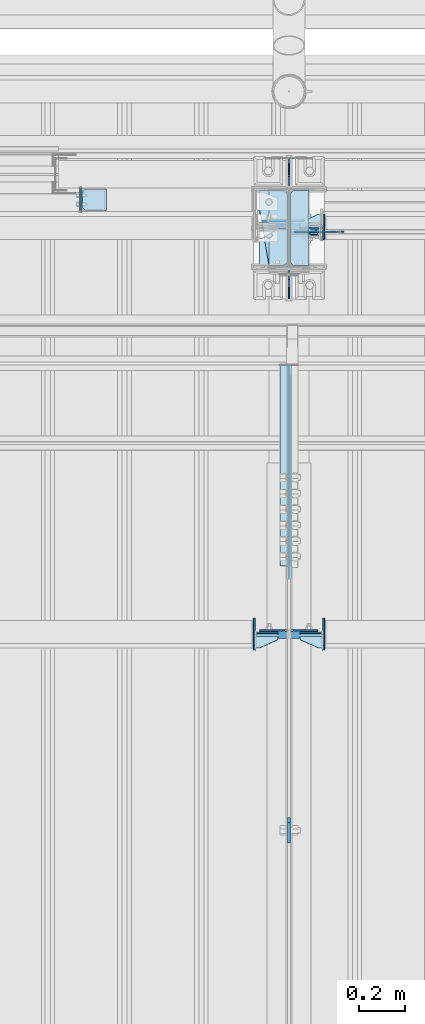
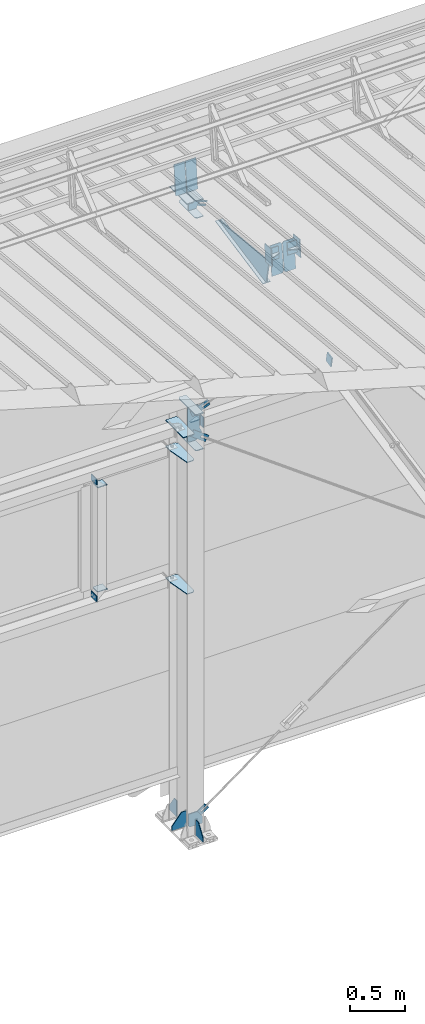
# One storey, part 139 of 709: 38 plates, 13 elements without a shape of their own.
"""IFC4 building model written with IfcOpenShell, lengths in millimetres."""

from ifc_helpers import new_model, si_unit, direction, frame, origin_with_axes, place, context, subcontext, project, spatial, line, indexed_curve, outline, extrude, material, element, aggregate, save


model = new_model("IFC4")

# Units and contexts
model_context = context("Model", 3, precision=0.2, world=origin_with_axes(), true_north=direction((0.0, 1.0)))
body_context = subcontext(model_context, "Body", "Model", "MODEL_VIEW")
ifc_project = project(units=[si_unit("LENGTHUNIT", "METRE", prefix="MILLI"), si_unit("AREAUNIT", "SQUARE_METRE"), si_unit("VOLUMEUNIT", "CUBIC_METRE"), si_unit("MASSUNIT", "GRAM", prefix="KILO"), si_unit("TIMEUNIT", "SECOND"), si_unit("PLANEANGLEUNIT", "RADIAN"), si_unit("SOLIDANGLEUNIT", "STERADIAN"), si_unit("THERMODYNAMICTEMPERATUREUNIT", "DEGREE_CELSIUS"), si_unit("LUMINOUSINTENSITYUNIT", "LUMEN")], contexts=[model_context])

# Site, building, storey
site_placement = place(None, origin_with_axes())
site = spatial("IfcSite", under=ifc_project, at=site_placement, CompositionType="ELEMENT")
building_placement = place(site_placement, origin_with_axes())
building = spatial("IfcBuilding", under=site, at=building_placement, Name="Undefined", CompositionType="ELEMENT")
storey_placement = place(building_placement, origin_with_axes())
storey = spatial("IfcBuildingStorey", under=building, at=storey_placement, Name="Undefined", CompositionType="ELEMENT", Elevation=0.0)

# Assembly, plates
assembly_1_placement = place(storey_placement, frame((22000.0, 21654.0, 7089.70002), z_axis=(-1.0, 0.0, 0.0), x_axis=(0.0, -0.9950371902, 0.099503719)))
assembly_1 = element("IfcElementAssembly", 1, at=assembly_1_placement, inside=storey)
ifc_material = material(Name="C355-6", Category="STEEL")
plate_1_placement = place(assembly_1_placement, frame((1597.88359, 163.0, -127.0), z_axis=(1.0, 0.0, 0.0), x_axis=(0.0, 0.0, 1.0)))
plate_1 = element("IfcPlate", 2, at=plate_1_placement, material=ifc_material, ObjectType="585", context=body_context, shape_type="SolidModel", body=[
    extrude(outline(indexed_curve([(0.0, 0.0), (108.0, 0.0), (123.0, 15.0), (123.0, 311.0), (108.0, 326.0), (0.0, 326.0)], segments=[line(1, 2, 3, 4, 5, 6, 1)])), frame((0.0, 0.0, 4.0), z_axis=(0.0, 0.0, 1.0), x_axis=(1.0, 0.0, 0.0)), (0.0, 0.0, -1.0), 8.0),
])
plate_2_placement = place(assembly_1_placement, frame((1597.88359, 163.0, 127.0), z_axis=(-1.0, 0.0, 0.0), x_axis=(0.0, 0.0, -1.0)))
plate_2 = element("IfcPlate", 3, at=plate_2_placement, material=ifc_material, ObjectType="585", context=body_context, shape_type="SolidModel", body=[
    extrude(outline(indexed_curve([(0.0, 0.0), (108.0, 0.0), (123.0, 15.0), (123.0, 311.0), (108.0, 326.0), (0.0, 326.0)], segments=[line(1, 2, 3, 4, 5, 6, 1)])), frame((0.0, 0.0, 4.0), z_axis=(0.0, 0.0, 1.0), x_axis=(1.0, 0.0, 0.0)), (0.0, 0.0, -1.0), 8.0),
])
plate_3_placement = place(assembly_1_placement, frame((1336.51563, -171.28713, 0.0), z_axis=(0.0, 0.0, 1.0), x_axis=(-1.0, 0.0, 0.0)))
plate_3 = element("IfcPlate", 4, at=plate_3_placement, material=ifc_material, ObjectType="449", context=body_context, shape_type="SolidModel", body=[
    extrude(outline(indexed_curve([(0.0, 0.0), (928.3198, 0.0), (79.53997, 259.83056)], segments=[line(1, 2, 3, 1)])), frame((0.0, 0.0, 6.0), z_axis=(0.0, 0.0, 1.0), x_axis=(1.0, 0.0, 0.0)), (0.0, 0.0, -1.0), 12.0),
])
plate_4_placement = place(assembly_1_placement, frame((1255.8048, -434.94249, -40.0), z_axis=(0.2927142719, 0.9561999556, 0.0), x_axis=(-0.9561999556, 0.2927142719, 0.0)))
plate_4 = element("IfcPlate", 5, at=plate_4_placement, material=ifc_material, ObjectType="450", context=body_context, shape_type="SolidModel", body=[
    extrude(outline(indexed_curve([(0.0, 0.0), (887.65935, 0.0), (887.65935, 80.0), (0.0, 80.0)], segments=[line(1, 2, 3, 4, 1)])), frame((0.0, 0.0, 4.0), z_axis=(0.0, 0.0, 1.0), x_axis=(1.0, 0.0, 0.0)), (0.0, 0.0, -1.0), 8.0),
])
aggregate(assembly_1, [plate_1, plate_2, plate_3, plate_4])

# Assembly, plate
assembly_2_placement = place(storey_placement, frame((22000.0, 19245.35924, 6685.17103), z_axis=(1.0, 0.0, 0.0), x_axis=(0.0, -0.9805806757, -0.1961161349)))
assembly_2 = element("IfcElementAssembly", 6, at=assembly_2_placement, inside=storey)
plate_5_placement = place(assembly_2_placement, origin_with_axes())
plate_5 = element("IfcPlate", 7, at=plate_5_placement, material=ifc_material, ObjectType="491", context=body_context, shape_type="SolidModel", body=[
    extrude(outline(indexed_curve([(0.0, 0.0), (90.0, 0.0), (90.0, 110.0), (0.0, 110.0)], segments=[line(1, 2, 3, 4, 1)])), frame((0.0, 0.0, 6.0), z_axis=(0.0, 0.0, 1.0), x_axis=(1.0, 0.0, 0.0)), (0.0, 0.0, -1.0), 12.0),
])
aggregate(assembly_2, [plate_5])

# Assembly, plates
assembly_3_placement = place(storey_placement, frame((28000.0, 21827.0, 4310.0), z_axis=(0.0, 0.0, -1.0), x_axis=(-1.0, 0.0, 0.0)))
assembly_3 = element("IfcElementAssembly", 8, at=assembly_3_placement, inside=storey)
plate_6_placement = place(assembly_3_placement, frame((5849.0, -50.0, -60.0), z_axis=(1.0, 0.0, 0.0), x_axis=(0.0, 1.0, 0.0)))
plate_6 = element("IfcPlate", 9, at=plate_6_placement, material=ifc_material, ObjectType="519", context=body_context, shape_type="SolidModel", body=[
    extrude(outline(indexed_curve([(0.0, 0.0), (110.0, 0.0), (110.0, 120.0), (0.0, 120.0)], segments=[line(1, 2, 3, 4, 1)])), frame((0.0, 0.0, 4.0), z_axis=(0.0, 0.0, 1.0), x_axis=(1.0, 0.0, 0.0)), (0.0, 0.0, -1.0), 8.0),
])
plate_7_placement = place(assembly_3_placement, frame((5953.0, 60.0, 0.0), z_axis=(0.0, 0.0, -1.0), x_axis=(0.0, -1.0, 0.0)))
plate_7 = element("IfcPlate", 10, at=plate_7_placement, material=ifc_material, ObjectType="521", context=body_context, shape_type="SolidModel", body=[
    extrude(outline(indexed_curve([(0.0, 80.0), (36.0, 0.0), (56.0, 0.0), (56.0, 90.0), (46.0, 100.0), (0.0, 100.0)], segments=[line(1, 2, 3, 4, 5, 6, 1)])), frame((0.0, 0.0, 4.0), z_axis=(0.0, 0.0, 1.0), x_axis=(1.0, 0.0, 0.0)), (0.0, 0.0, -1.0), 8.0),
])
plate_8_placement = place(assembly_3_placement, frame((5953.0, 0.0, -60.0), z_axis=(0.0, -1.0, 0.0), x_axis=(0.0, 0.0, 1.0)))
plate_8 = element("IfcPlate", 11, at=plate_8_placement, material=ifc_material, ObjectType="520", context=body_context, shape_type="SolidModel", body=[
    extrude(outline(indexed_curve([(0.0, 0.0), (120.0, 0.0), (120.0, 100.0), (0.0, 100.0)], segments=[line(1, 2, 3, 4, 1)])), frame((0.0, 0.0, 4.0), z_axis=(0.0, 0.0, 1.0), x_axis=(1.0, 0.0, 0.0)), (0.0, 0.0, -1.0), 8.0),
])
aggregate(assembly_3, [plate_6, plate_7, plate_8])

# Assembly, plate
assembly_4_placement = place(storey_placement, frame((26870.92374, 21811.0, 672.76012), z_axis=(0.0, 1.0, 0.0), x_axis=(-0.8064830392, 0.0, 0.5912572262)))
assembly_4 = element("IfcElementAssembly", 12, at=assembly_4_placement, inside=storey)
plate_9_placement = place(assembly_4_placement, frame((5781.83429, 35.0, 0.0), z_axis=(0.0, 0.0, -1.0), x_axis=(1.0, 0.0, 0.0)))
plate_9 = element("IfcPlate", 13, at=plate_9_placement, material=ifc_material, ObjectType="525", context=body_context, shape_type="SolidModel", body=[
    extrude(outline(indexed_curve([(0.0, 0.0), (200.0, 0.0), (200.0, 70.0), (0.0, 70.0), (0.0, 46.0), (80.0, 46.0), (80.0, 24.0), (0.0, 24.0)], segments=[line(1, 2, 3, 4, 5, 6, 7, 8, 1)])), frame((0.0, 0.0, 4.0), z_axis=(0.0, 0.0, 1.0), x_axis=(1.0, 0.0, 0.0)), (0.0, 0.0, -1.0), 8.0),
])
aggregate(assembly_4, [plate_9])

assembly_5_placement = place(storey_placement, frame((23129.07626, 21811.0, 672.76012), z_axis=(0.0, 1.0, 0.0), x_axis=(-0.8064830392, 0.0, -0.5912572261)))
assembly_5 = element("IfcElementAssembly", 14, at=assembly_5_placement, inside=storey)
plate_10_placement = place(assembly_5_placement, frame((1145.82155, 11.0, 0.0), z_axis=(0.0, 0.0, 1.0), x_axis=(1.0, 0.0, 0.0)))
plate_10 = element("IfcPlate", 15, at=plate_10_placement, material=ifc_material, ObjectType="490", context=body_context, shape_type="SolidModel", body=[
    extrude(outline(indexed_curve([(0.0, 0.0), (80.0, 0.0), (80.0, -22.0), (0.0, -22.0), (0.0, -46.0), (200.0, -46.0), (200.0, 24.0), (0.0, 24.0)], segments=[line(1, 2, 3, 4, 5, 6, 7, 8, 1)])), frame((0.0, 0.0, 4.0), z_axis=(0.0, 0.0, 1.0), x_axis=(1.0, 0.0, 0.0)), (0.0, 0.0, -1.0), 8.0),
])
aggregate(assembly_5, [plate_10])

assembly_6_placement = place(storey_placement, frame((26612.9509, 21811.0, 4959.49238), z_axis=(0.0, 1.0, 0.0), x_axis=(-0.9286065, 0.0, 0.371065989)))
assembly_6 = element("IfcElementAssembly", 16, at=assembly_6_placement, inside=storey)
plate_11_placement = place(assembly_6_placement, frame((4750.84953, -11.0, 0.0), z_axis=(0.0, 0.0, -1.0), x_axis=(1.0, 0.0, 0.0)))
plate_11 = element("IfcPlate", 17, at=plate_11_placement, material=ifc_material, ObjectType="556", context=body_context, shape_type="SolidModel", body=[
    extrude(outline(indexed_curve([(0.0, 0.0), (80.0, 0.0), (80.0, -22.0), (0.0, -22.0), (0.0, -41.0), (180.0, -41.0), (180.0, 19.0), (0.0, 19.0)], segments=[line(1, 2, 3, 4, 5, 6, 7, 8, 1)])), frame((0.0, 0.0, 4.0), z_axis=(0.0, 0.0, 1.0), x_axis=(1.0, 0.0, 0.0)), (0.0, 0.0, -1.0), 8.0),
])
aggregate(assembly_6, [plate_11])

assembly_7_placement = place(storey_placement, frame((23387.0491, 21811.0, 4959.49238), z_axis=(0.0, 1.0, 0.0), x_axis=(-0.9286065, 0.0, -0.371065989)))
assembly_7 = element("IfcElementAssembly", 18, at=assembly_7_placement, inside=storey)
plate_12_placement = place(assembly_7_placement, frame((1250.0, 35.0, 0.0), z_axis=(0.0, 0.0, -1.0), x_axis=(1.0, 0.0, 0.0)))
plate_12 = element("IfcPlate", 19, at=plate_12_placement, material=ifc_material, ObjectType="525", context=body_context, shape_type="SolidModel", body=[
    extrude(outline(indexed_curve([(0.0, 0.0), (200.0, 0.0), (200.0, 70.0), (0.0, 70.0), (0.0, 46.0), (80.0, 46.0), (80.0, 24.0), (0.0, 24.0)], segments=[line(1, 2, 3, 4, 5, 6, 7, 8, 1)])), frame((0.0, 0.0, 4.0), z_axis=(0.0, 0.0, 1.0), x_axis=(1.0, 0.0, 0.0)), (0.0, 0.0, -1.0), 8.0),
])
aggregate(assembly_7, [plate_12])

# Assembly, plates
assembly_8_placement = place(storey_placement, frame((22000.0, 21827.0, -200.0), z_axis=(-1.0, 0.0, 0.0), x_axis=(0.0, 0.0, 1.0)))
assembly_8 = element("IfcElementAssembly", 20, at=assembly_8_placement, inside=storey)
plate_13_placement = place(assembly_8_placement, frame((7434.21546, 30.02526, -3.0), z_axis=(-0.099503719, 0.9950371902, 0.0), x_axis=(0.0, 0.0, -1.0)))
plate_13 = element("IfcPlate", 21, at=plate_13_placement, material=ifc_material, ObjectType="595", context=body_context, shape_type="SolidModel", body=[
    extrude(outline(indexed_curve([(0.0, 0.0), (114.0, 0.0), (114.0, 333.33554), (0.0, 333.33554)], segments=[line(1, 2, 3, 4, 1)])), frame((0.0, 0.0, 4.0), z_axis=(0.0, 0.0, 1.0), x_axis=(1.0, 0.0, 0.0)), (0.0, 0.0, -1.0), 8.0),
])
plate_14_placement = place(assembly_8_placement, frame((7434.21546, 30.02526, 3.0), z_axis=(0.099503719, -0.9950371902, 0.0), x_axis=(0.0, 0.0, 1.0)))
plate_14 = element("IfcPlate", 22, at=plate_14_placement, material=ifc_material, ObjectType="595", context=body_context, shape_type="SolidModel", body=[
    extrude(outline(indexed_curve([(0.0, 0.0), (114.0, 0.0), (114.0, 332.53554), (0.0, 332.53554)], segments=[line(1, 2, 3, 4, 1)])), frame((0.0, 0.0, 4.0), z_axis=(0.0, 0.0, 1.0), x_axis=(1.0, 0.0, 0.0)), (0.0, 0.0, -1.0), 8.0),
])
plate_15_placement = place(assembly_8_placement, frame((4502.0, 163.0, 127.0), z_axis=(-1.0, 0.0, 0.0), x_axis=(0.0, 0.0, -1.0)))
plate_15 = element("IfcPlate", 23, at=plate_15_placement, material=ifc_material, ObjectType="547", context=body_context, shape_type="SolidModel", body=[
    extrude(outline(indexed_curve([(0.0, 0.0), (108.0, 0.0), (123.0, 15.0), (123.0, 311.0), (108.0, 326.0), (0.0, 326.0)], segments=[line(1, 2, 3, 4, 5, 6, 1)])), frame((0.0, 0.0, 4.0), z_axis=(0.0, 0.0, 1.0), x_axis=(1.0, 0.0, 0.0)), (0.0, 0.0, -1.0), 8.0),
])
plate_16_placement = place(assembly_8_placement, frame((4212.0, 163.0, 4.0), z_axis=(1.0, 0.0, 0.0), x_axis=(0.0, 0.0, 1.0)))
plate_16 = element("IfcPlate", 24, at=plate_16_placement, material=ifc_material, ObjectType="543", context=body_context, shape_type="SolidModel", body=[
    extrude(outline(indexed_curve([(0.0, 20.0), (20.0, 0.0), (123.0, 0.0), (123.0, 86.0), (83.0, 326.0), (20.0, 326.0), (0.0, 306.0)], segments=[line(1, 2, 3, 4, 5, 6, 7, 1)])), frame((0.0, 0.0, 4.0), z_axis=(0.0, 0.0, 1.0), x_axis=(1.0, 0.0, 0.0)), (0.0, 0.0, -1.0), 8.0),
])
plate_17_placement = place(assembly_8_placement, frame((2742.0, 163.0, 4.0), z_axis=(1.0, 0.0, 0.0), x_axis=(0.0, 0.0, 1.0)))
plate_17 = element("IfcPlate", 25, at=plate_17_placement, material=ifc_material, ObjectType="543", context=body_context, shape_type="SolidModel", body=[
    extrude(outline(indexed_curve([(0.0, 20.0), (20.0, 0.0), (123.0, 0.0), (123.0, 86.0), (83.0, 326.0), (20.0, 326.0), (0.0, 306.0)], segments=[line(1, 2, 3, 4, 5, 6, 7, 1)])), frame((0.0, 0.0, 4.0), z_axis=(0.0, 0.0, 1.0), x_axis=(1.0, 0.0, 0.0)), (0.0, 0.0, -1.0), 8.0),
])
plate_18_placement = place(assembly_8_placement, frame((6931.61775, -23.99306, -97.28783), z_axis=(-5.5187e-06, -0.9999998141, 0.0006097898), x_axis=(0.9286064751, -0.000231397, -0.3710659791)))
plate_18 = element("IfcPlate", 26, at=plate_18_placement, material=ifc_material, Name="PLATE", ObjectType="555", context=body_context, shape_type="SolidModel", body=[
    extrude(outline(indexed_curve([(0.0, 0.0), (70.0, 0.0), (146.9134, 69.78458), (115.74386, 147.78751), (-55.02687, 79.54846), (-23.23974, 0.0)], segments=[line(1, 2, 3, 4, 5, 6, 1)])), frame((0.0, 0.0, 4.0), z_axis=(0.0, 0.0, 1.0), x_axis=(1.0, 0.0, 0.0)), (0.0, 0.0, -1.0), 8.0),
])
plate_19_placement = place(assembly_8_placement, frame((4700.34059, -10.0, -116.73236), z_axis=(0.0, 1.0, 0.0), x_axis=(-0.9286065, 0.0, -0.371065989)))
plate_19 = element("IfcPlate", 27, at=plate_19_placement, material=ifc_material, ObjectType="552", context=body_context, shape_type="SolidModel", body=[
    extrude(outline(indexed_curve([(0.0, 0.0), (90.0, 0.0), (115.55903, 35.1197), (245.56394, 87.06894), (305.02493, 81.82799), (352.68082, 158.17533), (321.98714, 234.98741), (302.49206, 243.35051), (-28.27311, 111.17859), (-36.63622, 91.68351)], segments=[line(1, 2, 3, 4, 5, 6, 7, 8, 9, 10, 1)])), frame((0.0, 0.0, 6.0), z_axis=(0.0, 0.0, 1.0), x_axis=(1.0, 0.0, 0.0)), (0.0, 0.0, -1.0), 12.0),
])
plate_20_placement = place(assembly_8_placement, frame((4308.1454, -163.0, -87.0), z_axis=(-1.0, 0.0, 0.0), x_axis=(0.0, 0.0, 1.0)))
plate_20 = element("IfcPlate", 28, at=plate_20_placement, material=ifc_material, ObjectType="554", context=body_context, shape_type="SolidModel", body=[
    extrude(outline(indexed_curve([(0.0, 0.0), (68.0, 0.0), (83.0, 15.0), (83.0, 311.0), (68.0, 326.0), (0.0, 326.0)], segments=[line(1, 2, 3, 4, 5, 6, 1)])), frame((0.0, 0.0, 4.0), z_axis=(0.0, 0.0, 1.0), x_axis=(1.0, 0.0, 0.0)), (0.0, 0.0, -1.0), 8.0),
])
plate_21_placement = place(assembly_8_placement, frame((99.86739, -26.0, -150.94888), z_axis=(0.0, -1.0, 0.0), x_axis=(0.8064830392, 0.0, 0.5912572262)))
plate_21 = element("IfcPlate", 29, at=plate_21_placement, material=ifc_material, ObjectType="551", context=body_context, shape_type="SolidModel", body=[
    extrude(outline(indexed_curve([(0.0, 0.0), (90.0, 0.0), (146.01319, 76.40276), (39.19381, 154.71529), (18.22771, 151.4869), (-60.37928, 44.26588)], segments=[line(1, 2, 3, 4, 5, 6, 1)])), frame((0.0, 0.0, 6.0), z_axis=(0.0, 0.0, 1.0), x_axis=(1.0, 0.0, 0.0)), (0.0, 0.0, -1.0), 12.0),
])
plate_22_placement = place(assembly_8_placement, frame((6906.03718, -163.0, -87.0), z_axis=(-1.0, 0.0, 0.0), x_axis=(0.0, 0.0, 1.0)))
plate_22 = element("IfcPlate", 30, at=plate_22_placement, material=ifc_material, ObjectType="461", context=body_context, shape_type="SolidModel", body=[
    extrude(outline(indexed_curve([(0.0, 0.0), (68.0, 0.0), (83.0, 15.0), (83.0, 311.0), (68.0, 326.0), (0.0, 326.0)], segments=[line(1, 2, 3, 4, 5, 6, 1)])), frame((0.0, 0.0, 4.0), z_axis=(0.0, 0.0, 1.0), x_axis=(1.0, 0.0, 0.0)), (0.0, 0.0, -1.0), 8.0),
])
plate_23_placement = place(assembly_8_placement, frame((7097.93718, 163.0, 87.0), z_axis=(-1.0, 0.0, 0.0), x_axis=(0.0, 0.0, -1.0)))
plate_23 = element("IfcPlate", 31, at=plate_23_placement, material=ifc_material, ObjectType="461", context=body_context, shape_type="SolidModel", body=[
    extrude(outline(indexed_curve([(0.0, 0.0), (68.0, 0.0), (83.0, 15.0), (83.0, 311.0), (68.0, 326.0), (0.0, 326.0)], segments=[line(1, 2, 3, 4, 5, 6, 1)])), frame((0.0, 0.0, 4.0), z_axis=(0.0, 0.0, 1.0), x_axis=(1.0, 0.0, 0.0)), (0.0, 0.0, -1.0), 8.0),
])
plate_24_placement = place(assembly_8_placement, frame((7097.93718, -163.0, -87.0), z_axis=(-1.0, 0.0, 0.0), x_axis=(0.0, 0.0, 1.0)))
plate_24 = element("IfcPlate", 32, at=plate_24_placement, material=ifc_material, ObjectType="461", context=body_context, shape_type="SolidModel", body=[
    extrude(outline(indexed_curve([(0.0, 0.0), (68.0, 0.0), (83.0, 15.0), (83.0, 311.0), (68.0, 326.0), (0.0, 326.0)], segments=[line(1, 2, 3, 4, 5, 6, 1)])), frame((0.0, 0.0, 4.0), z_axis=(0.0, 0.0, 1.0), x_axis=(1.0, 0.0, 0.0)), (0.0, 0.0, -1.0), 8.0),
])
plate_25_placement = place(assembly_8_placement, frame((25.0, -173.0, 0.0), z_axis=(0.0, 0.0, 1.0), x_axis=(0.0, -1.0, 0.0)))
plate_25 = element("IfcPlate", 33, at=plate_25_placement, material=ifc_material, ObjectType="418", context=body_context, shape_type="SolidModel", body=[
    extrude(outline(indexed_curve([(0.0, 0.0), (135.0, 0.0), (135.0, 50.0), (50.0, 175.0), (0.0, 175.0)], segments=[line(1, 2, 3, 4, 5, 1)])), frame((0.0, 0.0, 4.0), z_axis=(0.0, 0.0, 1.0), x_axis=(1.0, 0.0, 0.0)), (0.0, 0.0, -1.0), 8.0),
])
plate_26_placement = place(assembly_8_placement, frame((25.0, 173.0, 0.0), z_axis=(0.0, 0.0, -1.0), x_axis=(0.0, 1.0, 0.0)))
plate_26 = element("IfcPlate", 34, at=plate_26_placement, material=ifc_material, ObjectType="418", context=body_context, shape_type="SolidModel", body=[
    extrude(outline(indexed_curve([(0.0, 0.0), (135.0, 0.0), (135.0, 50.0), (50.0, 175.0), (0.0, 175.0)], segments=[line(1, 2, 3, 4, 5, 1)])), frame((0.0, 0.0, 4.0), z_axis=(0.0, 0.0, 1.0), x_axis=(1.0, 0.0, 0.0)), (0.0, 0.0, -1.0), 8.0),
])
plate_27_placement = place(assembly_8_placement, frame((4706.34059, -163.0, -87.0), z_axis=(-1.0, 0.0, 0.0), x_axis=(0.0, 0.0, 1.0)))
plate_27 = element("IfcPlate", 35, at=plate_27_placement, material=ifc_material, ObjectType="553", context=body_context, shape_type="SolidModel", body=[
    extrude(outline(indexed_curve([(0.0, 0.0), (68.0, 0.0), (83.0, 15.0), (83.0, 311.0), (68.0, 326.0), (0.0, 326.0)], segments=[line(1, 2, 3, 4, 5, 6, 1)])), frame((0.0, 0.0, 6.0), z_axis=(0.0, 0.0, 1.0), x_axis=(1.0, 0.0, 0.0)), (0.0, 0.0, -1.0), 12.0),
])
plate_28_placement = place(assembly_8_placement, frame((25.0, 0.0, 3.0), z_axis=(0.0, 1.0, 0.0), x_axis=(0.0, 0.0, 1.0)))
plate_28 = element("IfcPlate", 36, at=plate_28_placement, material=ifc_material, ObjectType="417", context=body_context, shape_type="SolidModel", body=[
    extrude(outline(indexed_curve([(0.0, 0.0), (152.0, 0.0), (152.0, 50.0), (50.0, 175.0), (0.0, 175.0)], segments=[line(1, 2, 3, 4, 5, 1)])), frame((0.0, 0.0, 4.0), z_axis=(0.0, 0.0, 1.0), x_axis=(1.0, 0.0, 0.0)), (0.0, 0.0, -1.0), 8.0),
])
aggregate(assembly_8, [plate_13, plate_14, plate_15, plate_16, plate_17, plate_18, plate_19, plate_20, plate_21, plate_22, plate_23, plate_24, plate_25, plate_26, plate_27, plate_28])

# Assembly, plate
assembly_9_placement = place(storey_placement, frame((22000.0, 21950.0, 2550.0), z_axis=(0.0, 0.0, -1.0), x_axis=(-1.0, 0.0, 0.0)))
assembly_9 = element("IfcElementAssembly", 37, at=assembly_9_placement, inside=storey)
plate_29_placement = place(assembly_9_placement, frame((904.0, 50.0, -50.0), z_axis=(-1.0, 0.0, 0.0), x_axis=(0.0, 0.0, -1.0)))
plate_29 = element("IfcPlate", 38, at=plate_29_placement, material=ifc_material, ObjectType="509", context=body_context, shape_type="SolidModel", body=[
    extrude(outline(indexed_curve([(0.0, 0.0), (65.0, 0.0), (65.0, 100.0), (0.0, 100.0)], segments=[line(1, 2, 3, 4, 1)])), frame((0.0, 0.0, 4.0), z_axis=(0.0, 0.0, 1.0), x_axis=(1.0, 0.0, 0.0)), (0.0, 0.0, -1.0), 8.0),
])
aggregate(assembly_9, [plate_29])

assembly_10_placement = place(storey_placement, frame((22000.0, 21950.0, 4020.0), z_axis=(0.0, 0.0, -1.0), x_axis=(-1.0, 0.0, 0.0)))
assembly_10 = element("IfcElementAssembly", 39, at=assembly_10_placement, inside=storey)
plate_30_placement = place(assembly_10_placement, frame((904.0, -50.0, 50.0), z_axis=(-1.0, 0.0, 0.0), x_axis=(0.0, 0.0, 1.0)))
plate_30 = element("IfcPlate", 40, at=plate_30_placement, material=ifc_material, ObjectType="509", context=body_context, shape_type="SolidModel", body=[
    extrude(outline(indexed_curve([(0.0, 0.0), (65.0, 0.0), (65.0, 100.0), (0.0, 100.0)], segments=[line(1, 2, 3, 4, 1)])), frame((0.0, 0.0, 4.0), z_axis=(0.0, 0.0, 1.0), x_axis=(1.0, 0.0, 0.0)), (0.0, 0.0, -1.0), 8.0),
])
aggregate(assembly_10, [plate_30])

# Assembly, plates
assembly_11_placement = place(storey_placement, frame((21150.0, 21950.0, 2600.0), z_axis=(-1.0, 0.0, 0.0), x_axis=(0.0, 0.0, 1.0)))
assembly_11 = element("IfcElementAssembly", 41, at=assembly_11_placement, inside=storey)
plate_31_placement = place(assembly_11_placement, frame((103.0, -46.0, 46.0), z_axis=(-1.0, 0.0, 0.0), x_axis=(0.0, 1.0, 0.0)))
plate_31 = element("IfcPlate", 42, at=plate_31_placement, material=ifc_material, ObjectType="510", context=body_context, shape_type="SolidModel", body=[
    extrude(outline(indexed_curve([(0.0, 10.0), (10.0, 0.0), (82.0, 0.0), (92.0, 10.0), (92.0, 104.0), (0.0, 104.0)], segments=[line(1, 2, 3, 4, 5, 6, 1)])), frame((0.0, 0.0, 4.0), z_axis=(0.0, 0.0, 1.0), x_axis=(1.0, 0.0, 0.0)), (0.0, 0.0, -1.0), 8.0),
])
plate_32_placement = place(assembly_11_placement, frame((1267.0, 46.0, 46.0), z_axis=(1.0, 0.0, 0.0), x_axis=(0.0, -1.0, 0.0)))
plate_32 = element("IfcPlate", 43, at=plate_32_placement, material=ifc_material, ObjectType="510", context=body_context, shape_type="SolidModel", body=[
    extrude(outline(indexed_curve([(0.0, 10.0), (10.0, 0.0), (82.0, 0.0), (92.0, 10.0), (92.0, 104.0), (0.0, 104.0)], segments=[line(1, 2, 3, 4, 5, 6, 1)])), frame((0.0, 0.0, 4.0), z_axis=(0.0, 0.0, 1.0), x_axis=(1.0, 0.0, 0.0)), (0.0, 0.0, -1.0), 8.0),
])
aggregate(assembly_11, [plate_31, plate_32])

assembly_12_placement = place(storey_placement, frame((22000.0, 20063.34988, 7322.12913), z_axis=(0.0, -0.9950371902, 0.099503719), x_axis=(-1.0, 0.0, 0.0)))
assembly_12 = element("IfcElementAssembly", 44, at=assembly_12_placement, inside=storey)
plate_33_placement = place(assembly_12_placement, frame((151.0, -98.0, -60.0), z_axis=(-1.0, 0.0, 0.0), x_axis=(0.0, 0.0, 1.0)))
plate_33 = element("IfcPlate", 45, at=plate_33_placement, material=ifc_material, ObjectType="586", context=body_context, shape_type="SolidModel", body=[
    extrude(outline(indexed_curve([(0.0, 0.0), (120.0, 0.0), (120.0, 196.0), (0.0, 196.0)], segments=[line(1, 2, 3, 4, 1)])), frame((0.0, 0.0, 4.0), z_axis=(0.0, 0.0, 1.0), x_axis=(1.0, 0.0, 0.0)), (0.0, 0.0, -1.0), 8.0),
])
plate_34_placement = place(assembly_12_placement, frame((47.0, -65.0, 0.0), z_axis=(0.0, 0.0, 1.0), x_axis=(1.0, 0.0, 0.0)))
plate_34 = element("IfcPlate", 46, at=plate_34_placement, material=ifc_material, ObjectType="587", context=body_context, shape_type="SolidModel", body=[
    extrude(outline(indexed_curve([(0.0, 0.0), (100.0, 0.0), (100.0, 130.0), (0.0, 130.0)], segments=[line(1, 2, 3, 4, 1)])), frame((0.0, 0.0, 4.0), z_axis=(0.0, 0.0, 1.0), x_axis=(1.0, 0.0, 0.0)), (0.0, 0.0, -1.0), 8.0),
])
plate_35_placement = place(assembly_12_placement, frame((47.0, 0.0, 60.0), z_axis=(0.0, 1.0, 0.0), x_axis=(1.0, 0.0, 0.0)))
plate_35 = element("IfcPlate", 47, at=plate_35_placement, material=ifc_material, ObjectType="588", context=body_context, shape_type="SolidModel", body=[
    extrude(outline(indexed_curve([(0.0, 36.0), (80.0, 0.0), (100.0, 0.0), (100.0, 56.0), (0.0, 56.0)], segments=[line(1, 2, 3, 4, 5, 1)])), frame((0.0, 0.0, 4.0), z_axis=(0.0, 0.0, 1.0), x_axis=(1.0, 0.0, 0.0)), (0.0, 0.0, -1.0), 8.0),
])
aggregate(assembly_12, [plate_33, plate_34, plate_35])

assembly_13_placement = place(storey_placement, frame((28000.0, 20063.34988, 7322.12913), z_axis=(0.0, -0.9950371902, 0.099503719), x_axis=(-1.0, 0.0, 0.0)))
assembly_13 = element("IfcElementAssembly", 48, at=assembly_13_placement, inside=storey)
plate_36_placement = place(assembly_13_placement, frame((5953.0, 0.0, 60.0), z_axis=(0.0, -1.0, 0.0), x_axis=(-1.0, 0.0, 0.0)))
plate_36 = element("IfcPlate", 49, at=plate_36_placement, material=ifc_material, ObjectType="588", context=body_context, shape_type="SolidModel", body=[
    extrude(outline(indexed_curve([(0.0, 36.0), (80.0, 0.0), (100.0, 0.0), (100.0, 56.0), (0.0, 56.0)], segments=[line(1, 2, 3, 4, 5, 1)])), frame((0.0, 0.0, 4.0), z_axis=(0.0, 0.0, 1.0), x_axis=(1.0, 0.0, 0.0)), (0.0, 0.0, -1.0), 8.0),
])
plate_37_placement = place(assembly_13_placement, frame((5953.0, 65.0, 0.0), z_axis=(0.0, 0.0, 1.0), x_axis=(-1.0, 0.0, 0.0)))
plate_37 = element("IfcPlate", 50, at=plate_37_placement, material=ifc_material, ObjectType="587", context=body_context, shape_type="SolidModel", body=[
    extrude(outline(indexed_curve([(0.0, 0.0), (100.0, 0.0), (100.0, 130.0), (0.0, 130.0)], segments=[line(1, 2, 3, 4, 1)])), frame((0.0, 0.0, 4.0), z_axis=(0.0, 0.0, 1.0), x_axis=(1.0, 0.0, 0.0)), (0.0, 0.0, -1.0), 8.0),
])
plate_38_placement = place(assembly_13_placement, frame((5849.0, -98.0, 60.0), z_axis=(1.0, 0.0, 0.0), x_axis=(0.0, 0.0, -1.0)))
plate_38 = element("IfcPlate", 51, at=plate_38_placement, material=ifc_material, ObjectType="586", context=body_context, shape_type="SolidModel", body=[
    extrude(outline(indexed_curve([(0.0, 0.0), (120.0, 0.0), (120.0, 196.0), (0.0, 196.0)], segments=[line(1, 2, 3, 4, 1)])), frame((0.0, 0.0, 4.0), z_axis=(0.0, 0.0, 1.0), x_axis=(1.0, 0.0, 0.0)), (0.0, 0.0, -1.0), 8.0),
])
aggregate(assembly_13, [plate_36, plate_37, plate_38])

save(model, "model.ifc")
